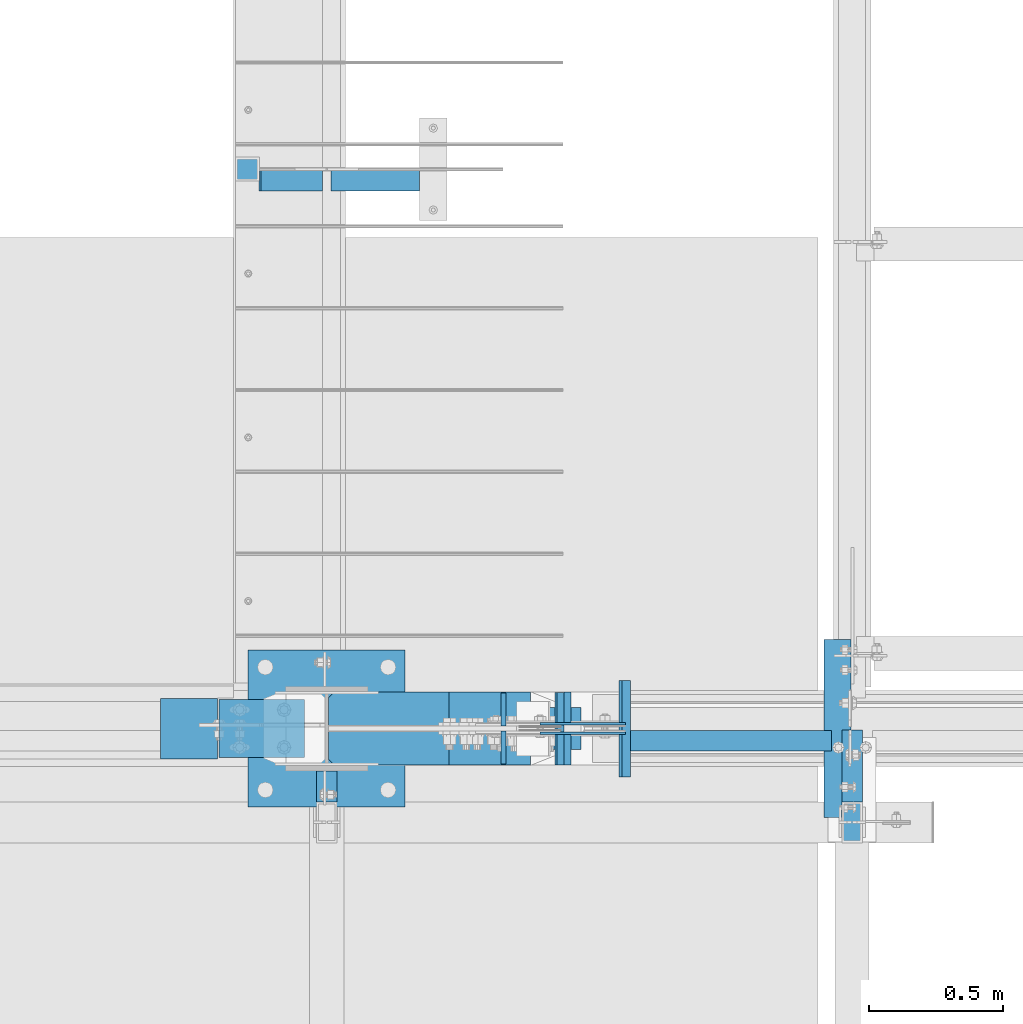
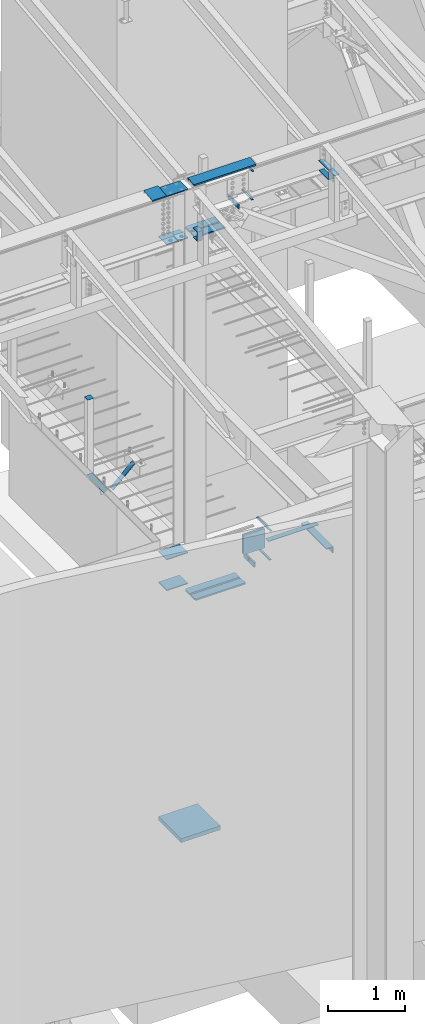
# One storey, part 815 of 1179: 27 beams, 2 members, 15 elements without a shape of their own.
"""IFC2X3 building model written with IfcOpenShell, lengths in millimetres."""

import ifcopenshell
import ifcopenshell.guid

model = None  # the IFC model being written
_history = None  # IfcOwnerHistory: only IFC2X3 demands one
_inside = {}  # id of a spatial element -> (the spatial element, [elements in it])
_under = {}  # id of a project, library or spatial element -> (it, [spatial elements below it])
_declared = {}  # id of a project -> (the project, [libraries it declares])
_typed = {}  # id of a type object -> (the type object, [elements of that type])
_made_of = {}  # id of a material, layer set ... -> (it, [elements and type objects made of it])


def new_model(schema):
    """Start an empty IFC model of exactly this schema.

    Asked for "IFC4X3", IfcOpenShell would pick the latest addendum, in which some entities
    have other attributes; the version numbers below select the first issue.
    IFC2X3 requires an IfcOwnerHistory on every rooted entity: one is made here for all.
    """
    global model, _history
    if schema == "IFC4X3":
        model = ifcopenshell.file(schema_version=(4, 3, 0, 0))
    else:
        model = ifcopenshell.file(schema=schema)
    _inside.clear()
    _under.clear()
    _declared.clear()
    _typed.clear()
    _made_of.clear()
    _history = None
    if model.schema == "IFC2X3":
        org = make("IfcOrganization", Name="unknown")
        user = make(
            "IfcPersonAndOrganization",
            ThePerson=make("IfcPerson", FamilyName="unknown"),
            TheOrganization=org,
        )
        app = make(
            "IfcApplication",
            ApplicationDeveloper=org,
            Version="unknown",
            ApplicationFullName="unknown",
            ApplicationIdentifier="unknown",
        )
        _history = make(
            "IfcOwnerHistory",
            OwningUser=user,
            OwningApplication=app,
            ChangeAction="ADDED",
            CreationDate=0,
        )
    return model


def make(cls, **values):
    """One entity of the class cls with the attributes given. An attribute that is None is left unset."""
    return model.create_entity(
        cls, **{name: value for name, value in values.items() if value is not None}
    )


def rooted(cls, **values):
    """An entity with a GlobalId (a new one), such as an element, a storey or a relation."""
    return make(cls, GlobalId=ifcopenshell.guid.new(), OwnerHistory=_history, **values)


def si_unit(unit_type, name, prefix=None):
    """IfcSIUnit, for example si_unit("LENGTHUNIT", "METRE", prefix="MILLI")."""
    return make("IfcSIUnit", UnitType=unit_type, Prefix=prefix, Name=name)


def assignment(units):
    """IfcUnitAssignment: the units of a project."""
    return None if units is None else make("IfcUnitAssignment", Units=units)


def point(xyz):
    """IfcCartesianPoint."""
    return None if xyz is None else make("IfcCartesianPoint", Coordinates=xyz)


def direction(xyz):
    """IfcDirection."""
    return None if xyz is None else make("IfcDirection", DirectionRatios=xyz)


def frame(location, z_axis=None, x_axis=None):
    """IfcAxis2Placement3D, a coordinate frame: its origin and axes. An axis left out is left unset."""
    return make(
        "IfcAxis2Placement3D",
        Location=point(location),
        Axis=direction(z_axis),
        RefDirection=direction(x_axis),
    )


def origin_with_axes():
    """The frame at (0, 0, 0) with the z axis (0, 0, 1) and the x axis (1, 0, 0) written out."""
    return frame((0.0, 0.0, 0.0), z_axis=(0.0, 0.0, 1.0), x_axis=(1.0, 0.0, 0.0))


def place(relative_to, where):
    """IfcLocalPlacement: puts the frame where relative to a parent placement (None: the world)."""
    return make(
        "IfcLocalPlacement", PlacementRelTo=relative_to, RelativePlacement=where
    )


def context(
    kind, dimensions, precision=None, world=None, true_north=None, identifier=None
):
    """IfcGeometricRepresentationContext, for example the 3D "Model" context."""
    return make(
        "IfcGeometricRepresentationContext",
        ContextIdentifier=identifier,
        ContextType=kind,
        CoordinateSpaceDimension=dimensions,
        Precision=precision,
        WorldCoordinateSystem=world,
        TrueNorth=true_north,
    )


def subcontext(parent, identifier, kind, view, scale=None):
    """IfcGeometricRepresentationSubContext, for example "Body" below "Model"."""
    return make(
        "IfcGeometricRepresentationSubContext",
        ContextIdentifier=identifier,
        ContextType=kind,
        ParentContext=parent,
        TargetScale=scale,
        TargetView=view,
    )


def project(units=None, contexts=None):
    """IfcProject with its units and contexts."""
    return rooted(
        "IfcProject",
        Name="project",
        RepresentationContexts=contexts,
        UnitsInContext=assignment(units),
    )


def spatial(cls, under=None, at=None, **own):
    """A site, building, storey or space (cls), placed at a placement, below another one or the project."""
    s = rooted(cls, ObjectPlacement=at, **own)
    if under is not None:
        _under.setdefault(under.id(), (under, []))[1].append(s)
    return s


def faces_of(points, faces, orient=None, outer=None):
    """IfcFace entities. A face is a list of loops; a loop is a list of indices into points, from 0.

    orient and outer hold one flag for each loop. By default every Orientation is true, the
    first loop of a face is its IfcFaceOuterBound and the others are IfcFaceBound.
    """
    made = []
    for i, loops in enumerate(faces):
        bounds = []
        for j, loop in enumerate(loops):
            is_outer = j == 0 if outer is None else outer[i][j]
            bounds.append(
                make(
                    "IfcFaceOuterBound" if is_outer else "IfcFaceBound",
                    Bound=make("IfcPolyLoop", Polygon=[points[k] for k in loop]),
                    Orientation=True if orient is None else orient[i][j],
                )
            )
        made.append(make("IfcFace", Bounds=bounds))
    return made


def faceted_brep(points, faces, orient=None, outer=None, voids=None):
    """IfcFacetedBrep: a solid bounded by flat faces; with voids (closed shells), ...WithVoids."""
    shared = [point(p) for p in points]
    hull = make("IfcClosedShell", CfsFaces=faces_of(shared, faces, orient, outer))
    if voids is None:
        return make("IfcFacetedBrep", Outer=hull)
    return make(
        "IfcFacetedBrepWithVoids",
        Outer=hull,
        Voids=[
            make(cls, CfsFaces=faces_of(shared, fs, o, b)) for cls, fs, o, b in voids
        ],
    )


def shape(context_of_items, identifier, shape_type, items):
    """IfcShapeRepresentation: the items that make up one representation, for example the "Body"."""
    return make(
        "IfcShapeRepresentation",
        ContextOfItems=context_of_items,
        RepresentationIdentifier=identifier,
        RepresentationType=shape_type,
        Items=items,
    )


def material(Name=None, Category=None):
    """IfcMaterial."""
    return make("IfcMaterial", Name=Name, Category=Category)


def made_of(thing, what):
    """Note that an element or type object is made of a material, layer set ...; save() writes the relation."""
    if what is not None:
        _made_of.setdefault(what.id(), (what, []))[1].append(thing)
    return thing


def type_object(cls, material=None, **own):
    """A type object (cls), such as IfcWallType, which elements share."""
    return made_of(rooted(cls, **own), material)


def element(
    cls,
    number,
    at=None,
    inside=None,
    cuts=None,
    type_object=None,
    material=None,
    context=None,
    identifier="Body",
    shape_type=None,
    held_by="IfcProductDefinitionShape",
    body=None,
    shapes=None,
    **own,
):
    """One element of the class cls, such as IfcWall. Its Tag is "e" and its number.

    at: its placement. inside: the storey or other place that contains it. cuts: it is an
    opening in that element (IfcRelVoidsElement). A single representation is given by context,
    identifier, shape_type and body (its items); several are given by shapes. held_by: the class
    of the entity that holds the representations. save() writes the other relations.
    """
    e = rooted(cls, Tag="e%d" % number, ObjectPlacement=at, **own)
    if body is not None:
        shapes = [shape(context, identifier, shape_type, body)]
    if shapes is not None:
        e.Representation = make(held_by, Representations=shapes)
    if inside is not None:
        _inside.setdefault(inside.id(), (inside, []))[1].append(e)
    if cuts is not None:
        rooted(
            "IfcRelVoidsElement", RelatingBuildingElement=cuts, RelatedOpeningElement=e
        )
    if type_object is not None:
        _typed.setdefault(type_object.id(), (type_object, []))[1].append(e)
    return made_of(e, material)


def aggregate(whole, parts):
    """IfcRelAggregates: a whole, such as a stair, and the parts it consists of."""
    return rooted("IfcRelAggregates", RelatingObject=whole, RelatedObjects=parts)


def save(model, path):
    """Write the relations noted so far, then the file.

    IfcRelAggregates (storeys below a building ...), IfcRelContainedInSpatialStructure (elements
    in a storey), IfcRelDefinesByType, IfcRelAssociatesMaterial and IfcRelDeclares: one each for
    every whole, place, type object, material and project.
    """
    for whole, parts in _under.values():
        aggregate(whole, parts)
    for where, things in _inside.values():
        rooted(
            "IfcRelContainedInSpatialStructure",
            RelatedElements=things,
            RelatingStructure=where,
        )
    for kind, things in _typed.values():
        rooted("IfcRelDefinesByType", RelatedObjects=things, RelatingType=kind)
    for what, things in _made_of.values():
        rooted("IfcRelAssociatesMaterial", RelatedObjects=things, RelatingMaterial=what)
    for by, libraries in _declared.values():
        rooted("IfcRelDeclares", RelatingContext=by, RelatedDefinitions=libraries)
    model.write(path)


model = new_model("IFC2X3")

# Units and contexts
model_context = context("Model", 3, precision=1e-05, world=origin_with_axes())
body_context = subcontext(model_context, "Body", "Model", "MODEL_VIEW")
ifc_project = project(units=[si_unit("LENGTHUNIT", "METRE", prefix="MILLI"), si_unit("AREAUNIT", "SQUARE_METRE"), si_unit("VOLUMEUNIT", "CUBIC_METRE"), si_unit("MASSUNIT", "GRAM", prefix="KILO"), si_unit("TIMEUNIT", "SECOND"), si_unit("PLANEANGLEUNIT", "RADIAN"), si_unit("SOLIDANGLEUNIT", "STERADIAN"), si_unit("THERMODYNAMICTEMPERATUREUNIT", "DEGREE_CELSIUS"), si_unit("LUMINOUSINTENSITYUNIT", "LUMEN")], contexts=[model_context])

# Site, building, storey
site_placement = place(None, origin_with_axes())
site = spatial("IfcSite", under=ifc_project, at=site_placement, CompositionType="ELEMENT")
building_placement = place(site_placement, origin_with_axes())
building = spatial("IfcBuilding", under=site, at=building_placement, Name="Undefined", CompositionType="ELEMENT")
storey_placement = place(building_placement, origin_with_axes())
storey = spatial("IfcBuildingStorey", under=building, at=storey_placement, Name="Undefined", CompositionType="ELEMENT", Elevation=0.0)

# Assembly, beam
assembly_1_placement = place(storey_placement, origin_with_axes())
assembly_1 = element("IfcElementAssembly", 1, at=assembly_1_placement, inside=storey, Name="BENT_PLATE", AssemblyPlace="NOTDEFINED", PredefinedType="RIGID_FRAME")
ifc_material_1 = material(Name="STEEL/A36")
beam_type_1 = type_object("IfcBeamType", PredefinedType="NOTDEFINED")
beam_1_placement = place(assembly_1_placement, frame((16941.7999995394, 5508.63433466315, 9826.91628331591), z_axis=(-1.0, 0.0, 0.0), x_axis=(0.0, 0.0, 1.0)))
beam_1 = element("IfcBeam", 2, at=beam_1_placement, type_object=beam_type_1, material=ifc_material_1, Name="BENT_PLATE", context=body_context, shape_type="Brep", body=[
    faceted_brep([(-2.72848410531878e-11, -4.76249999999982, -463.549999999999), (-2.72848410531878e-11, -4.76249999999982, 463.549999999999), (2.72848410531878e-11, 4.76249999999982, 463.549999999999), (2.72848410531878e-11, 4.76249999999982, -463.549999999999), (42.9704233751145, 4.76249999974698, 463.549999999999), (42.9704233751145, 4.76249999974698, -463.549999999999), (32.3091293513244, -4.7625000001899, -463.549999999999), (32.3091293513244, -4.7625000001899, 463.549999999999), (25.4000000081378, -150.812499999743, 463.549999999999), (25.4000000081378, -150.812499999743, -463.549999999999), (16.8901863966294, -141.287499999744, -463.549999999999), (16.8901863966294, -141.287499999744, 463.549999999999), (1.67201505973935e-08, -150.812499999746, 463.549999999999), (1.67201505973935e-08, -150.812499999746, -463.549999999999), (1.67201505973935e-08, -141.287499999747, 463.549999999999), (1.67201505973935e-08, -141.287499999747, -463.549999999999)], [[[0, 1, 2, 3]], [[3, 2, 4, 5]], [[1, 0, 6, 7]], [[5, 4, 8, 9]], [[7, 6, 10, 11]], [[9, 8, 12, 13]], [[8, 4, 2, 1, 7, 11, 14, 12]], [[11, 10, 15, 14]], [[10, 6, 0, 3, 5, 9, 13, 15]], [[14, 15, 13, 12]]]),
])
aggregate(assembly_1, [beam_1])

assembly_2_placement = place(storey_placement, origin_with_axes())
assembly_2 = element("IfcElementAssembly", 3, at=assembly_2_placement, inside=storey, Name="COLUMN", AssemblyPlace="NOTDEFINED", PredefinedType="RIGID_FRAME")
beam_type_2 = type_object("IfcBeamType", PredefinedType="NOTDEFINED")
beam_2_placement = place(assembly_2_placement, frame((18415.0, 5010.15, 9537.09726511864), z_axis=(1.0, 0.0, 0.0), x_axis=(0.0, 1.0, 0.0)))
beam_2 = element("IfcBeam", 4, at=beam_2_placement, type_object=beam_type_2, material=ifc_material_1, Name="PLATE", context=body_context, shape_type="Brep", body=[
    faceted_brep([(0.0, 2.38149999999951, -38.0999999999985), (0.0, 2.38149999999951, 38.0999999999985), (152.4, 2.38149999999951, 38.0999999999985), (152.4, 2.38149999999951, -38.0999999999985), (0.0, -2.38149999999951, 38.0999999999985), (152.4, -2.38149999999951, 38.0999999999985), (0.0, -2.38149999999951, -38.0999999999985), (152.4, -2.38149999999951, -38.0999999999985)], [[[0, 1, 2, 3]], [[1, 4, 5, 2]], [[4, 6, 7, 5]], [[6, 0, 3, 7]], [[5, 7, 3, 2]], [[6, 4, 1, 0]]]),
])
aggregate(assembly_2, [beam_2])

# Assembly, member
assembly_3_placement = place(storey_placement, origin_with_axes())
assembly_3 = element("IfcElementAssembly", 5, at=assembly_3_placement, inside=storey, Name="ANGLE", AssemblyPlace="NOTDEFINED", PredefinedType="RIGID_FRAME")
member_type = type_object("IfcMemberType", Name="L3X3X1/4", PredefinedType="NOTDEFINED")
member_1_placement = place(assembly_3_placement, frame((16501.4053723863, 7475.53750000001, 3750.22513768357), z_axis=(0.0, -1.0, 0.0), x_axis=(0.727253149038156, 0.0, 0.686369330036014)))
member_1 = element("IfcMember", 6, at=member_1_placement, type_object=member_type, material=ifc_material_1, Name="ANGLE", ObjectType="L3X3X1/4", context=body_context, shape_type="Brep", body=[
    faceted_brep([(0.0, 38.0999999999985, -38.0999999999999), (0.0, 38.0999999999985, 38.0999999999999), (453.790127309347, 38.1000000000822, 38.1000000000004), (453.790127309347, 38.1000000000822, -38.1000000000004), (0.0, 31.75, 38.1000000000004), (447.797103763844, 31.75000000008, 38.1000000000004), (0.0, 31.75, -31.75), (447.797103763844, 31.75000000008, -31.75), (0.0, -38.0999999999985, -31.75), (381.873844763302, -38.0999999999513, -31.75), (0.0, -38.0999999999985, -38.0999999999999), (381.873844763302, -38.0999999999513, -38.1000000000004)], [[[0, 1, 2, 3]], [[1, 4, 5, 2]], [[4, 6, 7, 5]], [[6, 8, 9, 7]], [[8, 10, 11, 9]], [[10, 0, 3, 11]], [[5, 7, 9, 11, 3, 2]], [[10, 8, 6, 4, 1, 0]]]),
])
aggregate(assembly_3, [member_1])

assembly_4_placement = place(storey_placement, origin_with_axes())
assembly_4 = element("IfcElementAssembly", 7, at=assembly_4_placement, inside=storey, Name="ANGLE", AssemblyPlace="NOTDEFINED", PredefinedType="RIGID_FRAME")
member_2_placement = place(assembly_4_placement, frame((16071.5088746262, 7475.53750000001, 4244.07051613347), z_axis=(0.0, -1.0, 0.0), x_axis=(0.563063038721371, 0.0, -0.826413948591054)))
member_2 = element("IfcMember", 8, at=member_2_placement, type_object=member_type, material=ifc_material_1, Name="ANGLE", ObjectType="L3X3X1/4", context=body_context, shape_type="Brep", body=[
    faceted_brep([(197.749830079142, 38.1000000001532, -38.1000000000004), (197.749830079142, 38.1000000001532, 38.1000000000004), (604.683435809257, 38.1000000004769, 38.1000000000004), (604.683435809257, 38.1000000004769, -38.1000000000004), (193.423365960303, 31.7500000001492, 38.1000000000004), (604.683435809257, 31.7500000004766, 38.1000000000004), (193.423365960303, 31.7500000001492, -31.75), (604.683435809257, 31.7500000004766, -31.75), (145.832260653064, -38.0999999998803, -31.75), (604.683435809262, -38.0999999995129, -31.75), (145.832260653064, -38.0999999998803, -38.1000000000004), (604.683435809262, -38.0999999995129, -38.1000000000004)], [[[0, 1, 2, 3]], [[1, 4, 5, 2]], [[4, 6, 7, 5]], [[6, 8, 9, 7]], [[8, 10, 11, 9]], [[10, 0, 3, 11]], [[5, 7, 9, 11, 3, 2]], [[10, 8, 6, 4, 1, 0]]]),
])
aggregate(assembly_4, [member_2])

# Assembly, beams
assembly_5_placement = place(storey_placement, origin_with_axes())
assembly_5 = element("IfcElementAssembly", 9, at=assembly_5_placement, inside=storey, Name="BEAM", AssemblyPlace="NOTDEFINED", PredefinedType="RIGID_FRAME")
beam_type_3 = type_object("IfcBeamType", Name="L4X4X1/2", PredefinedType="NOTDEFINED")
beam_3_placement = place(assembly_5_placement, frame((18361.0249999026, 5103.81250419475, 3578.225), z_axis=(0.0, 0.0, -1.0), x_axis=(0.0, 1.0, 0.0)))
beam_3 = element("IfcBeam", 10, at=beam_3_placement, type_object=beam_type_3, material=ifc_material_1, Name="ANGLE", ObjectType="L4X4X1/2", context=body_context, shape_type="Brep", body=[
    faceted_brep([(1.90993887372315e-11, 50.8000000000002, -50.8000000000002), (1.90993887372315e-11, 50.8000000000002, 50.8000000000002), (663.574996948242, 50.8000000000002, 50.8000000000002), (663.574996948242, 50.8000000000002, -50.8000000000002), (1.45519152283669e-11, 38.1000000000004, 50.8000000000002), (663.574996948242, 38.1000000000004, 50.8000000000002), (0.0, 38.0999999999985, -38.0999999999999), (663.574996948242, 38.1000000000004, -38.0999999999999), (-1.81898940354586e-11, -50.7999999999997, -38.0999999999999), (663.574996948242, -50.8000000000002, -38.0999999999999), (-1.81898940354586e-11, -50.7999999999997, -50.8000000000002), (663.574996948242, -50.8000000000002, -50.8000000000002)], [[[0, 1, 2, 3]], [[1, 4, 5, 2]], [[4, 6, 7, 5]], [[6, 8, 9, 7]], [[8, 10, 11, 9]], [[10, 0, 3, 11]], [[5, 7, 9, 11, 3, 2]], [[10, 8, 6, 4, 1, 0]]]),
])
ifc_material_2 = material(Name="STEEL/A572-GR.50")
beam_type_4 = type_object("IfcBeamType", PredefinedType="NOTDEFINED")
beam_4_placement = place(assembly_5_placement, frame((17579.0730116834, 5435.60003662087, 3624.2625), z_axis=(0.0, -1.0, 0.0), x_axis=(-1.0, 0.0, 0.0)))
beam_4 = element("IfcBeam", 11, at=beam_4_placement, type_object=beam_type_4, material=ifc_material_2, Name="PLATE", context=body_context, shape_type="Brep", body=[
    faceted_brep([(0.0, 4.76249999999982, -179.3875), (0.0, 4.76249999999982, 179.3875), (31.7500000000036, 4.76249999999982, 179.3875), (31.7500000000036, 4.76249999999982, -179.3875), (0.0, -4.76249999999982, 179.3875), (31.7500000000036, -4.76249999999982, 179.3875), (0.0, -4.76249999999982, -179.3875), (31.7500000000036, -4.76249999999982, -179.3875)], [[[0, 1, 2, 3]], [[1, 4, 5, 2]], [[4, 6, 7, 5]], [[6, 0, 3, 7]], [[5, 7, 3, 2]], [[6, 4, 1, 0]]]),
])
beam_5_placement = place(assembly_5_placement, frame((17590.185110306, 5435.60003662087, 4074.7155), z_axis=(0.0, -1.0, 0.0), x_axis=(-1.0, 0.0, 0.0)))
beam_5 = element("IfcBeam", 12, at=beam_5_placement, type_object=beam_type_4, material=ifc_material_2, Name="PLATE", context=body_context, shape_type="Brep", body=[
    faceted_brep([(0.0, 4.76249999999982, -179.3875), (0.0, 4.76249999999982, 179.3875), (31.7500000000036, 4.76249999999982, 179.3875), (31.7500000000036, 4.76249999999982, -179.3875), (0.0, -4.76249999999982, 179.3875), (31.7500000000036, -4.76249999999982, 179.3875), (0.0, -4.76249999999982, -179.3875), (31.7500000000036, -4.76249999999982, -179.3875)], [[[0, 1, 2, 3]], [[1, 4, 5, 2]], [[4, 6, 7, 5]], [[6, 0, 3, 7]], [[5, 7, 3, 2]], [[6, 4, 1, 0]]]),
])

# Assembly, beam
assembly_6_placement = place(storey_placement, origin_with_axes())
assembly_6 = element("IfcElementAssembly", 13, at=assembly_6_placement, inside=storey, Name="PLATE", AssemblyPlace="NOTDEFINED", PredefinedType="RIGID_FRAME")
beam_type_5 = type_object("IfcBeamType", PredefinedType="NOTDEFINED")
beam_6_placement = place(assembly_6_placement, frame((16465.5657844943, 5361.84824560525, 9059.64738620504), z_axis=(-3.34400000065216e-06, -0.999999999994409, 0.0), x_axis=(0.999999999994409, -3.34399999902627e-06, 0.0)))
beam_6 = element("IfcBeam", 14, at=beam_6_placement, type_object=beam_type_5, material=ifc_material_2, Name="PLATE", context=body_context, shape_type="Brep", body=[
    faceted_brep([(22.2249999998967, 9.52499999999964, 62.7065000000102), (-4.36557456851006e-11, 9.52499999999964, 40.4815000000044), (-4.36557456851006e-11, -9.52499999999964, 40.4815000000044), (22.2249999998967, -9.52499999999964, 62.7065000000102), (449.408058202138, 9.52499999999964, 62.7065000000557), (449.408058202265, 9.52499999999964, -62.7064999999611), (6.18456397205591e-11, 9.52499999999964, -62.7065000000084), (449.408058202138, -9.52499999999964, 62.7065000000557), (6.18456397205591e-11, -9.52499999999964, -62.7065000000084), (449.408058202265, -9.52499999999964, -62.7064999999611)], [[[0, 1, 2, 3]], [[4, 5, 6, 1, 0]], [[7, 4, 0, 3]], [[8, 9, 7, 3, 2]], [[8, 6, 5, 9]], [[7, 9, 5, 4]], [[6, 8, 2, 1]]]),
])
aggregate(assembly_6, [beam_6])

assembly_7_placement = place(storey_placement, origin_with_axes())
assembly_7 = element("IfcElementAssembly", 15, at=assembly_7_placement, inside=storey, Name="PLATE", AssemblyPlace="NOTDEFINED", PredefinedType="RIGID_FRAME")
beam_7_placement = place(assembly_7_placement, frame((16465.5657844943, 5509.35175439475, 9059.64738620504), z_axis=(-3.34400000065216e-06, 0.999999999994409, 0.0), x_axis=(0.999999999994409, 3.34399999902627e-06, 0.0)))
beam_7 = element("IfcBeam", 16, at=beam_7_placement, type_object=beam_type_5, material=ifc_material_2, Name="PLATE", context=body_context, shape_type="Brep", body=[
    faceted_brep([(22.2249999998967, 9.52499999999964, 62.7065000000102), (-4.36557456851006e-11, 9.52499999999964, 40.4815000000044), (-4.36557456851006e-11, -9.52499999999964, 40.4815000000044), (22.2249999998967, -9.52499999999964, 62.7065000000102), (449.408058202138, 9.52499999999964, 62.7065000000557), (449.408058202265, 9.52499999999964, -62.7064999999611), (6.18456397205591e-11, 9.52499999999964, -62.7065000000084), (449.408058202138, -9.52499999999964, 62.7065000000557), (6.18456397205591e-11, -9.52499999999964, -62.7065000000084), (449.408058202265, -9.52499999999964, -62.7064999999611)], [[[0, 1, 2, 3]], [[4, 5, 6, 1, 0]], [[7, 4, 0, 3]], [[8, 9, 7, 3, 2]], [[8, 6, 5, 9]], [[7, 9, 5, 4]], [[6, 8, 2, 1]]]),
])
aggregate(assembly_7, [beam_7])

assembly_8_placement = place(storey_placement, origin_with_axes())
assembly_8 = element("IfcElementAssembly", 17, at=assembly_8_placement, inside=storey, Name="COLUMN", AssemblyPlace="NOTDEFINED", PredefinedType="RIGID_FRAME")
beam_type_6 = type_object("IfcBeamType", PredefinedType="NOTDEFINED")
beam_8_placement = place(assembly_8_placement, frame((16163.925, 7473.95000000001, 5299.86900000003), z_axis=(1.0, 0.0, 0.0), x_axis=(0.0, 1.0, 0.0)))
beam_8 = element("IfcBeam", 18, at=beam_8_placement, type_object=beam_type_6, material=ifc_material_1, Name="PLATE", context=body_context, shape_type="Brep", body=[
    faceted_brep([(0.0, 2.38150000000041, -44.4500000000007), (0.0, 2.38150000000041, 44.4500000000007), (88.9000000000015, 2.38150000000041, 44.4500000000007), (88.9000000000015, 2.38150000000041, -44.4500000000007), (0.0, -2.38150000000041, 44.4500000000007), (88.9000000000015, -2.38150000000041, 44.4500000000007), (0.0, -2.38150000000041, -44.4500000000007), (88.9000000000015, -2.38150000000041, -44.4500000000007)], [[[0, 1, 2, 3]], [[1, 4, 5, 2]], [[4, 6, 7, 5]], [[6, 0, 3, 7]], [[5, 7, 3, 2]], [[6, 4, 1, 0]]]),
])
aggregate(assembly_8, [beam_8])

# Assembly, beams
assembly_9_placement = place(storey_placement, origin_with_axes())
assembly_9 = element("IfcElementAssembly", 19, at=assembly_9_placement, inside=storey, Name="COLUMN", AssemblyPlace="NOTDEFINED", PredefinedType="RIGID_FRAME")
beam_type_7 = type_object("IfcBeamType", PredefinedType="NOTDEFINED")
beam_9_placement = place(assembly_9_placement, frame((16376.6499999994, 5435.6, 9071.26628427711), z_axis=(0.0, 1.0, 0.0), x_axis=(-1.0, 0.0, 0.0)))
beam_9 = element("IfcBeam", 20, at=beam_9_placement, type_object=beam_type_7, material=ifc_material_2, Name="PLATE", context=body_context, shape_type="Brep", body=[
    faceted_brep([(0.0, 6.35000000000036, -107.949999999997), (0.0, 6.35000000000036, 107.949999999997), (317.5, 6.35000000000036, 107.949999999997), (317.5, 6.35000000000036, -107.949999999997), (0.0, -6.35000000000036, 107.949999999997), (317.5, -6.35000000000036, 107.949999999997), (0.0, -6.35000000000036, -107.949999999997), (317.5, -6.35000000000036, -107.949999999997)], [[[0, 1, 2, 3]], [[1, 4, 5, 2]], [[4, 6, 7, 5]], [[6, 0, 3, 7]], [[5, 7, 3, 2]], [[6, 4, 1, 0]]]),
])
beam_10_placement = place(assembly_9_placement, frame((16376.65, 5435.6, 9833.31678878201), z_axis=(0.0, 1.0, 0.0), x_axis=(-1.0, 0.0, 0.0)))
beam_10 = element("IfcBeam", 21, at=beam_10_placement, type_object=beam_type_7, material=ifc_material_2, Name="PLATE", context=body_context, shape_type="Brep", body=[
    faceted_brep([(0.0, 6.35000000000036, -107.949999999997), (0.0, 6.35000000000036, 107.949999999997), (317.5, 6.35000000000036, 107.949999999997), (317.5, 6.35000000000036, -107.949999999997), (0.0, -6.35000000000036, 107.949999999997), (317.5, -6.35000000000036, 107.949999999997), (0.0, -6.35000000000036, -107.949999999997), (317.5, -6.35000000000036, -107.949999999997)], [[[0, 1, 2, 3]], [[1, 4, 5, 2]], [[4, 6, 7, 5]], [[6, 0, 3, 7]], [[5, 7, 3, 2]], [[6, 4, 1, 0]]]),
])
beam_11_placement = place(assembly_9_placement, frame((16376.65, 5435.6, 3622.675), z_axis=(0.0, 1.0, 0.0), x_axis=(-1.0, 0.0, 0.0)))
beam_11 = element("IfcBeam", 22, at=beam_11_placement, type_object=beam_type_7, material=ifc_material_2, Name="PLATE", context=body_context, shape_type="Brep", body=[
    faceted_brep([(0.0, 6.35000000000036, -107.949999999997), (0.0, 6.35000000000036, 107.949999999997), (317.5, 6.35000000000036, 107.949999999997), (317.5, 6.35000000000036, -107.949999999997), (0.0, -6.35000000000036, 107.949999999997), (317.5, -6.35000000000036, 107.949999999997), (0.0, -6.35000000000036, -107.949999999997), (317.5, -6.35000000000036, -107.949999999997)], [[[0, 1, 2, 3]], [[1, 4, 5, 2]], [[4, 6, 7, 5]], [[6, 0, 3, 7]], [[5, 7, 3, 2]], [[6, 4, 1, 0]]]),
])
beam_12_placement = place(assembly_9_placement, frame((16376.65, 5435.6, 4108.45), z_axis=(0.0, 1.0, 0.0), x_axis=(-1.0, 0.0, 0.0)))
beam_12 = element("IfcBeam", 23, at=beam_12_placement, type_object=beam_type_7, material=ifc_material_2, Name="PLATE", context=body_context, shape_type="Brep", body=[
    faceted_brep([(0.0, 6.35000000000036, -107.949999999997), (0.0, 6.35000000000036, 107.949999999997), (317.5, 6.35000000000036, 107.949999999997), (317.5, 6.35000000000036, -107.949999999997), (0.0, -6.35000000000036, 107.949999999997), (317.5, -6.35000000000036, 107.949999999997), (0.0, -6.35000000000036, -107.949999999997), (317.5, -6.35000000000036, -107.949999999997)], [[[0, 1, 2, 3]], [[1, 4, 5, 2]], [[4, 6, 7, 5]], [[6, 0, 3, 7]], [[5, 7, 3, 2]], [[6, 4, 1, 0]]]),
])

assembly_10_placement = place(storey_placement, origin_with_axes())
assembly_10 = element("IfcElementAssembly", 24, at=assembly_10_placement, inside=storey, Name="BEAM", AssemblyPlace="NOTDEFINED", PredefinedType="RIGID_FRAME")
beam_type_8 = type_object("IfcBeamType", PredefinedType="NOTDEFINED")
beam_13_placement = place(assembly_10_placement, frame((17309.5025141307, 5435.60003656299, 9355.42878427283), z_axis=(-0.000242551999894204, -0.999999970584263, 0.0), x_axis=(0.999999970584263, -0.000242551999895156, 0.0)))
beam_13 = element("IfcBeam", 25, at=beam_13_placement, type_object=beam_type_8, material=ifc_material_2, Name="PLATE", context=body_context, shape_type="Brep", body=[
    faceted_brep([(7.27595761418343e-12, 4.76250000000437, -134.9375), (7.27595761418343e-12, 4.76250000000437, 134.9375), (25.3999999988191, 4.76250000000073, 134.937499999988), (25.3999999987645, 4.76250000000073, -134.937499999999), (-3.63797880709171e-12, -4.76249999999891, 134.9375), (25.3999999988191, -4.76250000000073, 134.937499999988), (-3.63797880709171e-12, -4.76249999999891, -134.9375), (25.3999999987645, -4.76250000000073, -134.937499999999)], [[[0, 1, 2, 3]], [[1, 4, 5, 2]], [[4, 6, 7, 5]], [[6, 0, 3, 7]], [[5, 7, 3, 2]], [[6, 4, 1, 0]]]),
])
beam_14_placement = place(assembly_10_placement, frame((17317.4400137562, 5435.60003656299, 9802.70678424828), z_axis=(-0.000242551999894204, -0.999999970584263, 0.0), x_axis=(0.999999970584263, -0.000242551999895156, 0.0)))
beam_14 = element("IfcBeam", 26, at=beam_14_placement, type_object=beam_type_8, material=ifc_material_2, Name="PLATE", context=body_context, shape_type="Brep", body=[
    faceted_brep([(7.27595761418343e-12, 4.76250000000437, -134.9375), (7.27595761418343e-12, 4.76250000000437, 134.9375), (25.3999999988191, 4.76250000000073, 134.937499999988), (25.3999999987645, 4.76250000000073, -134.937499999999), (-3.63797880709171e-12, -4.76249999999891, 134.9375), (25.3999999988191, -4.76250000000073, 134.937499999988), (-3.63797880709171e-12, -4.76249999999891, -134.9375), (25.3999999987645, -4.76250000000073, -134.937499999999)], [[[0, 1, 2, 3]], [[1, 4, 5, 2]], [[4, 6, 7, 5]], [[6, 0, 3, 7]], [[5, 7, 3, 2]], [[6, 4, 1, 0]]]),
])

# Beam
beam_type_9 = type_object("IfcBeamType", PredefinedType="NOTDEFINED")
beam_15_placement = place(assembly_9_placement, frame((16459.2, 5278.4375, 9242.7162842795), z_axis=(-1.0, 0.0, 0.0), x_axis=(0.0, -1.0, 0.0)))
beam_15 = element("IfcBeam", 27, at=beam_15_placement, type_object=beam_type_9, material=ifc_material_1, Name="BENT_PLATE", context=body_context, shape_type="Brep", body=[
    faceted_brep([(0.0, -3.17499999999927, -38.0999999999985), (0.0, -3.17499999999927, 38.0999999999985), (0.0, 3.17499999999927, 38.0999999999985), (0.0, 3.17499999999927, -38.0999999999985), (115.887499991678, 3.17499999999927, 38.0999999999985), (115.887499991678, 3.17499999999927, -38.0999999999985), (109.537499992024, -3.17499999999927, -38.0999999999985), (109.537499992024, -3.17499999999927, 38.0999999999985), (115.887500000001, -149.225000000002, 38.0999999999985), (115.887500000001, -149.225000000002, -38.0999999999985), (109.537499999654, -142.875000000004, -38.0999999999985), (109.537499999654, -142.875000000004, 38.0999999999985), (0.0, -149.225000000002, 38.0999999999985), (0.0, -149.225000000002, -38.0999999999985), (0.0, -142.875000000004, 38.0999999999985), (0.0, -142.875000000004, -38.0999999999985)], [[[0, 1, 2, 3]], [[3, 2, 4, 5]], [[1, 0, 6, 7]], [[5, 4, 8, 9]], [[7, 6, 10, 11]], [[9, 8, 12, 13]], [[8, 4, 2, 1, 7, 11, 14, 12]], [[11, 10, 15, 14]], [[10, 6, 0, 3, 5, 9, 13, 15]], [[14, 15, 13, 12]]]),
])

beam_16_placement = place(assembly_10_placement, frame((18415.0, 5430.05308465637, 9528.4662842795), z_axis=(-1.0, 0.0, 0.0), x_axis=(0.0, -1.0, 0.0)))
beam_16 = element("IfcBeam", 28, at=beam_16_placement, type_object=beam_type_9, material=ifc_material_1, Name="BENT_PLATE", context=body_context, shape_type="Brep", body=[
    faceted_brep([(0.0, -3.17499999999927, -38.0999999999985), (0.0, -3.17499999999927, 38.0999999999985), (0.0, 3.17499999999927, 38.0999999999985), (0.0, 3.17499999999927, -38.0999999999985), (267.503084648043, 3.17499999999927, 38.0999999999985), (267.503084648043, 3.17499999999927, -38.0999999999985), (261.153084648389, -3.17499999999927, -38.0999999999985), (261.153084648389, -3.17499999999927, 38.0999999999985), (267.503084656366, -149.225000000002, 38.0999999999985), (267.503084656366, -149.225000000002, -38.0999999999985), (261.153084656019, -142.875000000004, -38.0999999999985), (261.153084656019, -142.875000000004, 38.0999999999985), (19.0500000000002, -149.225000000002, 38.0999999999985), (19.0500000000002, -149.225000000002, -38.0999999999985), (19.0500000000002, -142.875000000004, 38.0999999999985), (19.0500000000002, -142.875000000004, -38.0999999999985)], [[[0, 1, 2, 3]], [[3, 2, 4, 5]], [[1, 0, 6, 7]], [[5, 4, 8, 9]], [[7, 6, 10, 11]], [[9, 8, 12, 13]], [[8, 4, 2, 1, 7, 11, 14, 12]], [[11, 10, 15, 14]], [[10, 6, 0, 3, 5, 9, 13, 15]], [[14, 15, 13, 12]]]),
])

aggregate(assembly_10, [beam_13, beam_16, beam_14])

# Assembly, beam
assembly_11_placement = place(storey_placement, origin_with_axes())
assembly_11 = element("IfcElementAssembly", 29, at=assembly_11_placement, inside=storey, Name="PLATE", AssemblyPlace="NOTDEFINED", PredefinedType="RIGID_FRAME")
beam_type_10 = type_object("IfcBeamType", PredefinedType="NOTDEFINED")
beam_17_placement = place(assembly_11_placement, frame((16465.5499999999, 5360.1935, 3345.89037683261), z_axis=(0.0, 1.0, 0.0), x_axis=(1.0, 0.0, 0.0)))
beam_17 = element("IfcBeam", 30, at=beam_17_placement, type_object=beam_type_10, material=ifc_material_2, Name="PLATE", context=body_context, shape_type="Brep", body=[
    faceted_brep([(22.2249999999985, -12.6999999999998, -61.1189999999997), (0.0, -12.6999999999998, -38.8940000000002), (0.0, 12.6999999999998, -38.8940000000002), (22.2249999999985, 12.6999999999998, -61.1189999999997), (0.0, 12.7, 61.1189999999988), (752.956604848459, 12.6999999999998, 61.1189999999997), (752.956604848459, 12.6999999999998, -61.1189999999997), (0.0, -12.7, 61.1189999999988), (752.956604848459, -12.6999999999998, 61.1189999999997), (752.956604848459, -12.6999999999998, -61.1189999999997)], [[[0, 1, 2, 3]], [[4, 5, 6, 3, 2]], [[4, 7, 8, 5]], [[9, 8, 7, 1, 0]], [[6, 9, 0, 3]], [[8, 9, 6, 5]], [[7, 4, 2, 1]]]),
])
aggregate(assembly_11, [beam_17])

assembly_12_placement = place(storey_placement, origin_with_axes())
assembly_12 = element("IfcElementAssembly", 31, at=assembly_12_placement, inside=storey, Name="PLATE", AssemblyPlace="NOTDEFINED", PredefinedType="RIGID_FRAME")
beam_18_placement = place(assembly_12_placement, frame((16465.5499999999, 5511.0065, 3345.89037683261), z_axis=(0.0, -1.0, 0.0), x_axis=(1.0, 0.0, 0.0)))
beam_18 = element("IfcBeam", 32, at=beam_18_placement, type_object=beam_type_10, material=ifc_material_2, Name="PLATE", context=body_context, shape_type="Brep", body=[
    faceted_brep([(22.2249999999985, -12.6999999999998, -61.1189999999997), (0.0, -12.6999999999998, -38.8940000000002), (0.0, 12.6999999999998, -38.8940000000002), (22.2249999999985, 12.6999999999998, -61.1189999999997), (0.0, 12.7, 61.1189999999988), (752.956604848459, 12.6999999999998, 61.1189999999997), (752.956604848459, 12.6999999999998, -61.1189999999997), (0.0, -12.7, 61.1189999999988), (752.956604848459, -12.6999999999998, 61.1189999999997), (752.956604848459, -12.6999999999998, -61.1189999999997)], [[[0, 1, 2, 3]], [[4, 5, 6, 3, 2]], [[4, 7, 8, 5]], [[9, 8, 7, 1, 0]], [[6, 9, 0, 3]], [[8, 9, 6, 5]], [[7, 4, 2, 1]]]),
])
aggregate(assembly_12, [beam_18])

assembly_13_placement = place(storey_placement, origin_with_axes())
assembly_13 = element("IfcElementAssembly", 33, at=assembly_13_placement, inside=storey, Name="PLATE", AssemblyPlace="NOTDEFINED", PredefinedType="RIGID_FRAME")
beam_type_11 = type_object("IfcBeamType", PredefinedType="NOTDEFINED")
beam_19_placement = place(assembly_13_placement, frame((17571.135110306, 5418.1375, 3865.5625), z_axis=(0.0, 0.0, -1.0), x_axis=(-1.0, 0.0, 0.0)))
beam_19 = element("IfcBeam", 34, at=beam_19_placement, type_object=beam_type_11, material=ifc_material_2, Name="PLATE", context=body_context, shape_type="Brep", body=[
    faceted_brep([(0.0, 4.76250000000073, -152.4), (0.0, 4.76250000000073, 152.4), (317.5, 4.76250000000073, 152.4), (317.5, 4.76250000000073, -152.4), (0.0, -4.76250000000073, 152.4), (317.5, -4.76250000000073, 152.4), (0.0, -4.76250000000073, -152.4), (317.5, -4.76250000000073, -152.4)], [[[0, 1, 2, 3]], [[1, 4, 5, 2]], [[4, 6, 7, 5]], [[6, 0, 3, 7]], [[5, 7, 3, 2]], [[6, 4, 1, 0]]]),
])
aggregate(assembly_13, [beam_19])

assembly_14_placement = place(storey_placement, origin_with_axes())
assembly_14 = element("IfcElementAssembly", 35, at=assembly_14_placement, inside=storey, Name="PLATE", AssemblyPlace="NOTDEFINED", PredefinedType="RIGID_FRAME")
beam_20_placement = place(assembly_14_placement, frame((17253.635110306, 5453.0625, 3865.5625), z_axis=(0.0, 0.0, -1.0), x_axis=(1.0, 0.0, 0.0)))
beam_20 = element("IfcBeam", 36, at=beam_20_placement, type_object=beam_type_11, material=ifc_material_2, Name="PLATE", context=body_context, shape_type="Brep", body=[
    faceted_brep([(0.0, 4.76250000000073, -152.4), (0.0, 4.76250000000073, 152.4), (317.5, 4.76250000000073, 152.4), (317.5, 4.76250000000073, -152.4), (0.0, -4.76250000000073, 152.4), (317.5, -4.76250000000073, 152.4), (0.0, -4.76250000000073, -152.4), (317.5, -4.76250000000073, -152.4)], [[[0, 1, 2, 3]], [[1, 4, 5, 2]], [[4, 6, 7, 5]], [[6, 0, 3, 7]], [[5, 7, 3, 2]], [[6, 4, 1, 0]]]),
])
aggregate(assembly_14, [beam_20])

# Beam
beam_type_12 = type_object("IfcBeamType", PredefinedType="NOTDEFINED")
beam_21_placement = place(assembly_9_placement, frame((17355.235110306, 5360.9875, 3629.025), z_axis=(0.0, 1.0, 0.0), x_axis=(0.0, 0.0, -1.0)))
beam_21 = element("IfcBeam", 37, at=beam_21_placement, type_object=beam_type_12, material=ifc_material_2, Name="PLATE", context=body_context, shape_type="Brep", body=[
    faceted_brep([(0.0, 12.7, -61.9124999999985), (0.0, 12.7, 61.9124999999985), (76.1999999999998, 12.7000000000007, 61.9125000000004), (76.1999999999998, 12.7000000000007, -61.9125000000004), (0.0, -12.7, 61.9124999999985), (76.1999999999998, -12.7000000000007, 61.9125000000004), (0.0, -12.7, -61.9124999999985), (76.1999999999998, -12.7000000000007, -61.9125000000004)], [[[0, 1, 2, 3]], [[1, 4, 5, 2]], [[4, 6, 7, 5]], [[6, 0, 3, 7]], [[5, 7, 3, 2]], [[6, 4, 1, 0]]]),
])

beam_22_placement = place(assembly_9_placement, frame((17355.235110306, 5510.2125, 3629.025), z_axis=(0.0, -1.0, 0.0), x_axis=(0.0, 0.0, -1.0)))
beam_22 = element("IfcBeam", 38, at=beam_22_placement, type_object=beam_type_12, material=ifc_material_2, Name="PLATE", context=body_context, shape_type="Brep", body=[
    faceted_brep([(0.0, 12.7, -61.9124999999985), (0.0, 12.7, 61.9124999999985), (76.1999999999998, 12.7000000000007, 61.9125000000004), (76.1999999999998, 12.7000000000007, -61.9125000000004), (0.0, -12.7, 61.9124999999985), (76.1999999999998, -12.7000000000007, 61.9125000000004), (0.0, -12.7, -61.9124999999985), (76.1999999999998, -12.7000000000007, -61.9125000000004)], [[[0, 1, 2, 3]], [[1, 4, 5, 2]], [[4, 6, 7, 5]], [[6, 0, 3, 7]], [[5, 7, 3, 2]], [[6, 4, 1, 0]]]),
])

beam_type_13 = type_object("IfcBeamType", PredefinedType="NOTDEFINED")
beam_23_placement = place(assembly_9_placement, frame((17117.4150188739, 5506.24618402658, 9360.18608511461), z_axis=(0.000242554000029486, 0.999999970115842, -3.05920298851561e-05), x_axis=(-1.26999993832602e-07, -3.05919999814988e-05, -0.999999999532057)))
beam_23 = element("IfcBeam", 39, at=beam_23_placement, type_object=beam_type_13, material=ifc_material_2, Name="PLATE", context=body_context, shape_type="Brep", body=[
    faceted_brep([(2.5465851649642e-11, 9.52500000002692, -61.1189999999951), (-3.8198777474463e-11, 9.52499999996144, 61.1190000000024), (76.2065601470313, 9.52499999982683, 61.1189999999824), (76.2065601470968, 9.52499999989232, -61.1190000000161), (-2.72848410531878e-11, -9.52500000003056, 61.1189999999951), (76.2065601470422, -9.5250000001688, 61.1189999999742), (3.63797880709171e-11, -9.52499999996508, -61.1190000000024), (76.2065601471077, -9.52500000009968, -61.1190000000242)], [[[0, 1, 2, 3]], [[1, 4, 5, 2]], [[4, 6, 7, 5]], [[6, 0, 3, 7]], [[5, 7, 3, 2]], [[6, 4, 1, 0]]]),
])

beam_24_placement = place(assembly_9_placement, frame((17117.4150188743, 5364.95614733437, 9360.1860853308), z_axis=(0.00024255399996764, 0.999999968859585, 5.87229674802075e-05), x_axis=(-1.26999977654868e-07, 5.87230000124994e-05, -0.999999998275797)))
beam_24 = element("IfcBeam", 40, at=beam_24_placement, type_object=beam_type_13, material=ifc_material_2, Name="PLATE", context=body_context, shape_type="Brep", body=[
    faceted_brep([(2.5465851649642e-11, 9.52500000002692, -61.1189999999951), (-3.8198777474463e-11, 9.52499999996144, 61.1190000000024), (76.2065601470313, 9.52499999982683, 61.1189999999824), (76.2065601470968, 9.52499999989232, -61.1190000000161), (-2.72848410531878e-11, -9.52500000003056, 61.1189999999951), (76.2065601470422, -9.5250000001688, 61.1189999999742), (3.63797880709171e-11, -9.52499999996508, -61.1190000000024), (76.2065601471077, -9.52500000009968, -61.1190000000242)], [[[0, 1, 2, 3]], [[1, 4, 5, 2]], [[4, 6, 7, 5]], [[6, 0, 3, 7]], [[5, 7, 3, 2]], [[6, 4, 1, 0]]]),
])

# Assembly, beam
assembly_15_placement = place(storey_placement, origin_with_axes())
assembly_15 = element("IfcElementAssembly", 41, at=assembly_15_placement, inside=storey, Name="BEAM", AssemblyPlace="NOTDEFINED", PredefinedType="RIGID_FRAME")
beam_type_14 = type_object("IfcBeamType", PredefinedType="NOTDEFINED")
beam_25_placement = place(assembly_15_placement, frame((15946.4374993246, 5543.55933465661, 9826.91628427538), z_axis=(-1.0, 0.0, 0.0), x_axis=(0.0, 0.0, 1.0)))
beam_25 = element("IfcBeam", 42, at=beam_25_placement, type_object=beam_type_14, material=ifc_material_1, Name="BENT_PLATE", context=body_context, shape_type="Brep", body=[
    faceted_brep([(-5.0931703299284e-11, -4.76249999999982, -106.362499999999), (-5.0931703299284e-11, -4.76249999999982, 106.362499999999), (5.0931703299284e-11, 4.76249999999982, 106.362499999999), (5.0931703299284e-11, 4.76249999999982, -106.362499999999), (46.9151565927532, 4.76249999949414, 106.362499999999), (46.9151565927532, 4.76249999949414, -106.362499999999), (36.2535597977621, -4.7625000003909, -106.362499999999), (36.2535597977621, -4.7625000003909, 106.362499999999), (21.4495292281481, -220.662499999491, 106.362499999999), (21.4495292281481, -220.662499999491, -106.362499999999), (12.9399572808561, -211.137499999592, -106.362499999999), (12.9399572808561, -211.137499999592, 106.362499999999), (8.24729795567691e-09, -220.662499999747, 106.362499999999), (8.24729795567691e-09, -220.662499999747, -106.362499999999), (8.13452061265707e-09, -211.137499999747, 106.362499999999), (8.13452061265707e-09, -211.137499999747, -106.362499999999)], [[[0, 1, 2, 3]], [[3, 2, 4, 5]], [[1, 0, 6, 7]], [[5, 4, 8, 9]], [[7, 6, 10, 11]], [[9, 8, 12, 13]], [[8, 4, 2, 1, 7, 11, 14, 12]], [[11, 10, 15, 14]], [[10, 6, 0, 3, 5, 9, 13, 15]], [[14, 15, 13, 12]]]),
])
aggregate(assembly_15, [beam_25])

# Beam
beam_type_15 = type_object("IfcBeamType", PredefinedType="NOTDEFINED")
beam_26_placement = place(assembly_5_placement, frame((17589.1349907081, 5390.35625, 3844.13071920033), z_axis=(0.0, 1.0, 0.0), x_axis=(1.0, 0.0, 0.0)))
beam_26 = element("IfcBeam", 43, at=beam_26_placement, type_object=beam_type_15, material=ifc_material_1, Name="PLATE", context=body_context, shape_type="Brep", body=[
    faceted_brep([(0.0, 3.96900000000005, -38.1000000000004), (0.0, 3.96900000000005, 38.1000000000004), (749.665009291904, 3.96900000003188, 38.1000000000004), (749.665009291904, 3.96900000003188, -38.1000000000004), (-3.63797880709171e-12, -3.96900000000005, 38.1000000000004), (749.665009291912, -3.96899999996822, 38.1000000000004), (-3.63797880709171e-12, -3.96900000000005, -38.1000000000004), (749.665009291912, -3.96899999996822, -38.1000000000004)], [[[0, 1, 2, 3]], [[1, 4, 5, 2]], [[4, 6, 7, 5]], [[6, 0, 3, 7]], [[5, 7, 3, 2]], [[6, 4, 1, 0]]]),
])

aggregate(assembly_5, [beam_4, beam_5, beam_26, beam_3])

beam_type_16 = type_object("IfcBeamType", PredefinedType="NOTDEFINED")
beam_27_placement = place(assembly_9_placement, frame((16167.10050354, 5435.6, -247.649999999999), z_axis=(0.0, 1.0, 0.0), x_axis=(1.0, 0.0, 0.0)))
beam_27 = element("IfcBeam", 44, at=beam_27_placement, type_object=beam_type_16, material=ifc_material_2, context=body_context, shape_type="Brep", body=[
    faceted_brep([(0.0, 31.75, -292.1), (0.0, 31.75, 292.1), (584.199496459958, 31.75, 292.1), (584.199496459958, 31.75, -292.1), (0.0, -31.75, 292.1), (584.199496459958, -31.75, 292.1), (0.0, -31.75, -292.1), (584.199496459958, -31.75, -292.1)], [[[0, 1, 2, 3]], [[1, 4, 5, 2]], [[4, 6, 7, 5]], [[6, 0, 3, 7]], [[5, 7, 3, 2]], [[6, 4, 1, 0]]]),
])

aggregate(assembly_9, [beam_15, beam_21, beam_22, beam_23, beam_24, beam_9, beam_10, beam_11, beam_12, beam_27])

save(model, "model.ifc")
